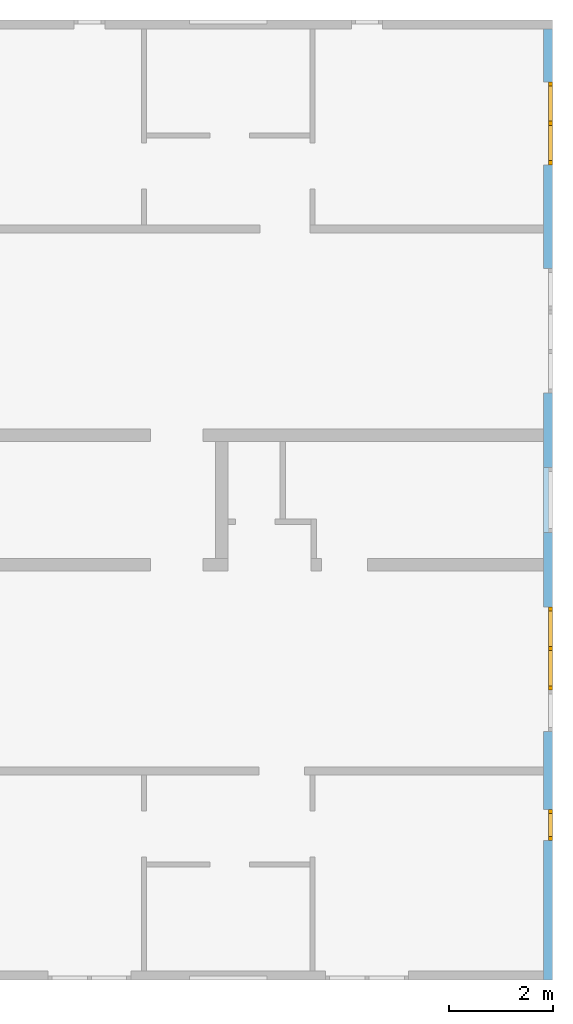
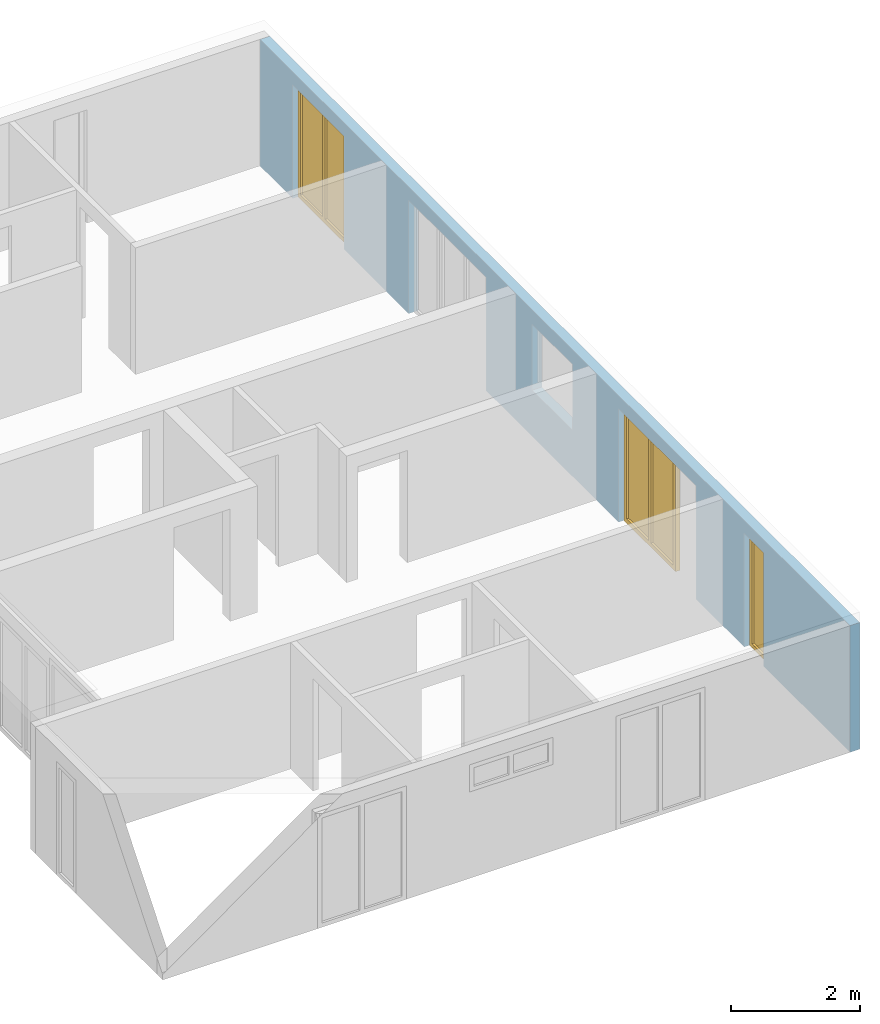
# One storey, part 6 of 8: 3 windows, 7 openings, plus 1 element that does not belong to this part.
"""IFC2X3 building model written with IfcOpenShell, lengths in millimetres."""

from ifc_helpers import new_model, entity, si_unit, converted_unit, frame, frame_2d, origin, origin_with_axes, place, context, project, spatial, rectangle, extrude, faceted_brep, material, layer, layer_set, layer_usage, element, fill, save


model = new_model("IFC2X3")

# Units and contexts
model_context = context("Model", 3, precision=1e-05, world=origin())
plan_context = context("Plan", 3, precision=1e-05, world=origin())
ifc_project = project(units=[si_unit("LENGTHUNIT", "METRE", prefix="MILLI"), converted_unit("PLANEANGLEUNIT", "DEGREE", entity("IfcPlaneAngleMeasure", 0.0174532925199433), si_unit("PLANEANGLEUNIT", "RADIAN"), dimensions=[0, 0, 0, 0, 0, 0, 0]), si_unit("AREAUNIT", "SQUARE_METRE"), si_unit("VOLUMEUNIT", "CUBIC_METRE")], contexts=[model_context, plan_context])

# Building, storey
building_placement = place(None, origin())
building = spatial("IfcBuilding", under=ifc_project, at=building_placement, CompositionType="ELEMENT")
storey_placement = place(building_placement, frame((0.0, 0.0, 2900.0), z_axis=(0.0, 0.0, 1.0), x_axis=(1.0, 0.0, 0.0)))
storey = spatial("IfcBuildingStorey", under=building, at=storey_placement, Name="OG", CompositionType="ELEMENT", Elevation=2900.0)

# Wall, openings, windows
ifc_material_1 = material(Name="B25")
ifc_layer = layer(ifc_material_1, 175.000000044703)
ifc_layer_set = layer_set([ifc_layer])
ifc_layer_usage = layer_usage(ifc_layer_set, "AXIS2", "POSITIVE", 0.0)
wall_placement = place(storey_placement, frame((33688.3517822139, -8691.5625, 0.0), z_axis=(0.0, 0.0, 1.0), x_axis=(0.0, 1.0, 0.0)))
wall = element("IfcWallStandardCase", 1, at=wall_placement, inside=storey, material=ifc_layer_usage, context=model_context, shape_type="SweptSolid", body=[
    extrude(rectangle(XDim=18325.0, YDim=175.000000044703, at=frame_2d((9162.5, 87.5000000223517), x_axis=(1.0, 0.0))), origin_with_axes(), (0.0, 0.0, 1.0), 2400.0),
])
opening_1_placement = place(wall_placement, frame((2690.0, 0.0, 0.0), z_axis=(0.0, 1.0, 0.0), x_axis=(0.0, 0.0, 1.0)))
opening_1 = element("IfcOpeningElement", 2, at=opening_1_placement, cuts=wall, ObjectType="Opening", context=model_context, shape_type="SweptSolid", body=[
    extrude(rectangle(XDim=2150.0, YDim=600.0, at=frame_2d((1075.0, 300.0), x_axis=(1.0, 0.0))), origin_with_axes(), (0.0, 0.0, 1.0), 175.000000044703),
])
opening_2_placement = place(wall_placement, frame((5590.0, 0.0, 0.0), z_axis=(0.0, 1.0, 0.0), x_axis=(0.0, 0.0, 1.0)))
opening_2 = element("IfcOpeningElement", 3, at=opening_2_placement, cuts=wall, ObjectType="Opening", context=model_context, shape_type="SweptSolid", body=[
    extrude(rectangle(XDim=2150.0, YDim=1600.0, at=frame_2d((1075.0, 800.0), x_axis=(1.0, 0.0))), origin_with_axes(), (0.0, 0.0, 1.0), 175.000000044703),
])
opening_3_placement = place(wall_placement, frame((15710.0, 0.0, 0.0), z_axis=(0.0, 1.0, 0.0), x_axis=(0.0, 0.0, 1.0)))
opening_3 = element("IfcOpeningElement", 4, at=opening_3_placement, cuts=wall, ObjectType="Opening", context=model_context, shape_type="SweptSolid", body=[
    extrude(rectangle(XDim=2150.0, YDim=1600.0, at=frame_2d((1075.0, 800.0), x_axis=(1.0, 0.0))), origin_with_axes(), (0.0, 0.0, 1.0), 175.000000044703),
])
opening_4_placement = place(wall_placement, frame((8625.0, 1.86264514923096e-09, 875.0), z_axis=(0.0, 1.0, 0.0), x_axis=(0.0, 0.0, 1.0)))
element("IfcOpeningElement", 5, at=opening_4_placement, cuts=wall, ObjectType="Opening", context=model_context, shape_type="SweptSolid", body=[
    extrude(rectangle(XDim=1250.0, YDim=1250.0, at=frame_2d((625.0, 625.0), x_axis=(1.0, 0.0))), origin_with_axes(), (0.0, 0.0, 1.0), 175.000000044703),
])
opening_5_placement = place(wall_placement, frame((4790.0, 0.0, 0.0), z_axis=(0.0, 1.0, 0.0), x_axis=(0.0, 0.0, 1.0)))
element("IfcOpeningElement", 6, at=opening_5_placement, cuts=wall, ObjectType="Opening", context=model_context, shape_type="SweptSolid", body=[
    extrude(rectangle(XDim=2150.0, YDim=800.0, at=frame_2d((1075.0, 400.0), x_axis=(1.0, 0.0))), origin_with_axes(), (0.0, 0.0, 1.0), 175.000000044703),
])
opening_6_placement = place(wall_placement, frame((12910.0, 0.0, 0.0), z_axis=(0.0, 1.0, 0.0), x_axis=(0.0, 0.0, 1.0)))
element("IfcOpeningElement", 7, at=opening_6_placement, cuts=wall, ObjectType="Opening", context=model_context, shape_type="SweptSolid", body=[
    extrude(rectangle(XDim=2150.0, YDim=800.0, at=frame_2d((1075.0, 400.0), x_axis=(1.0, 0.0))), origin_with_axes(), (0.0, 0.0, 1.0), 175.000000044703),
])
opening_7_placement = place(wall_placement, frame((11310.0, 0.0, 0.0), z_axis=(0.0, 1.0, 0.0), x_axis=(0.0, 0.0, 1.0)))
element("IfcOpeningElement", 8, at=opening_7_placement, cuts=wall, ObjectType="Opening", context=model_context, shape_type="SweptSolid", body=[
    extrude(rectangle(XDim=2150.0, YDim=1600.0, at=frame_2d((1075.0, 800.0), x_axis=(1.0, 0.0))), origin_with_axes(), (0.0, 0.0, 1.0), 175.000000044703),
])
ifc_material_2 = material()
window_1_placement = place(opening_1_placement, frame((0.0, 0.0, 0.0), z_axis=(1.0, 0.0, 0.0), x_axis=(0.0, 1.0, 0.0)))
window_1 = element("IfcWindow", 9, at=window_1_placement, inside=storey, material=ifc_material_2, Name="m", OverallHeight=2150.0, OverallWidth=600.0, context=model_context, shape_type="Brep", body=[
    faceted_brep([(520.0, 4.16384704493566e-11, 0.0), (520.0, 4.16384704493566e-11, 2150.0), (600.0, 4.16237044831291e-11, 2150.0), (600.0, 4.16237044831291e-11, 0.0), (600.0, 80.0000000000416, 0.0), (600.0, 80.0000000000416, 2150.0), (520.0, 80.0000000000416, 2150.0), (520.0, 80.0000000000416, 0.0), (600.0, 4.16237044831291e-11, 0.0), (600.0, 80.0000000000416, 0.0), (520.0, 80.0000000000416, 0.0), (520.0, 4.16384704493566e-11, 0.0), (600.0, 4.16237044831291e-11, 2150.0), (600.0, 80.0000000000416, 2150.0), (600.0, 80.0000000000416, 0.0), (600.0, 4.16237044831291e-11, 0.0), (520.0, 4.16384704493566e-11, 2150.0), (520.0, 80.0000000000416, 2150.0), (600.0, 80.0000000000416, 2150.0), (600.0, 4.16237044831291e-11, 2150.0), (520.0, 4.16384704493566e-11, 0.0), (520.0, 80.0000000000416, 0.0), (520.0, 80.0000000000416, 2150.0), (520.0, 4.16384704493566e-11, 2150.0)], [[[0, 1, 2, 3]], [[4, 5, 6, 7]], [[8, 9, 10, 11]], [[12, 13, 14, 15]], [[16, 17, 18, 19]], [[20, 21, 22, 23]]], orient=[[False], [False], [False], [False], [False], [False]]),
    faceted_brep([(80.0, 4.17335055402646e-11, 2150.0), (80.0, 4.17335055402646e-11, 0.0), (-1.10214571841424e-16, 4.17481604841896e-11, 0.0), (-1.10214571841424e-16, 4.17481604841896e-11, 2150.0), (1.45850616740271e-14, 80.0000000000418, 2150.0), (1.45850616740271e-14, 80.0000000000418, 0.0), (80.0, 80.0000000000417, 0.0), (80.0, 80.0000000000417, 2150.0), (-1.10214571841424e-16, 4.17481604841896e-11, 2150.0), (1.45850616740271e-14, 80.0000000000418, 2150.0), (80.0, 80.0000000000417, 2150.0), (80.0, 4.17335055402646e-11, 2150.0), (-1.10214571841424e-16, 4.17481604841896e-11, 0.0), (1.45850616740271e-14, 80.0000000000418, 0.0), (1.45850616740271e-14, 80.0000000000418, 2150.0), (-1.10214571841424e-16, 4.17481604841896e-11, 2150.0), (80.0, 4.17335055402646e-11, 0.0), (80.0, 80.0000000000417, 0.0), (1.45850616740271e-14, 80.0000000000418, 0.0), (-1.10214571841424e-16, 4.17481604841896e-11, 0.0), (80.0, 4.17335055402646e-11, 2150.0), (80.0, 80.0000000000417, 2150.0), (80.0, 80.0000000000417, 0.0), (80.0, 4.17335055402646e-11, 0.0)], [[[0, 1, 2, 3]], [[4, 5, 6, 7]], [[8, 9, 10, 11]], [[12, 13, 14, 15]], [[16, 17, 18, 19]], [[20, 21, 22, 23]]], orient=[[False], [False], [False], [False], [False], [False]]),
    faceted_brep([(520.0, 4.16668921587871e-11, 2070.0), (80.0, 4.17477163949798e-11, 2070.0), (80.0, 4.17477163949798e-11, 2150.0), (520.0, 4.16668921587871e-11, 2150.0), (520.0, 80.0000000000417, 2150.0), (80.0, 80.0000000000418, 2150.0), (80.0, 80.0000000000418, 2070.0), (520.0, 80.0000000000417, 2070.0), (520.0, 4.16668921587871e-11, 2150.0), (520.0, 80.0000000000417, 2150.0), (520.0, 80.0000000000417, 2070.0), (520.0, 4.16668921587871e-11, 2070.0), (80.0, 4.17477163949798e-11, 2150.0), (80.0, 80.0000000000418, 2150.0), (520.0, 80.0000000000417, 2150.0), (520.0, 4.16668921587871e-11, 2150.0), (80.0, 4.17477163949798e-11, 2070.0), (80.0, 80.0000000000418, 2070.0), (80.0, 80.0000000000418, 2150.0), (80.0, 4.17477163949798e-11, 2150.0), (520.0, 4.16668921587871e-11, 2070.0), (520.0, 80.0000000000417, 2070.0), (80.0, 80.0000000000418, 2070.0), (80.0, 4.17477163949798e-11, 2070.0)], [[[0, 1, 2, 3]], [[4, 5, 6, 7]], [[8, 9, 10, 11]], [[12, 13, 14, 15]], [[16, 17, 18, 19]], [[20, 21, 22, 23]]], orient=[[False], [False], [False], [False], [False], [False]]),
    faceted_brep([(80.0, 4.17477163949798e-11, 80.0), (520.0, 4.16668921587871e-11, 80.0), (520.0, 4.16668921587871e-11, 0.0), (80.0, 4.17477163949798e-11, 0.0), (80.0, 80.0000000000418, 0.0), (520.0, 80.0000000000417, 0.0), (520.0, 80.0000000000417, 80.0), (80.0, 80.0000000000418, 80.0), (80.0, 4.17477163949798e-11, 0.0), (80.0, 80.0000000000418, 0.0), (80.0, 80.0000000000418, 80.0), (80.0, 4.17477163949798e-11, 80.0), (520.0, 4.16668921587871e-11, 0.0), (520.0, 80.0000000000417, 0.0), (80.0, 80.0000000000418, 0.0), (80.0, 4.17477163949798e-11, 0.0), (520.0, 4.16668921587871e-11, 80.0), (520.0, 80.0000000000417, 80.0), (520.0, 80.0000000000417, 0.0), (520.0, 4.16668921587871e-11, 0.0), (80.0, 4.17477163949798e-11, 80.0), (80.0, 80.0000000000418, 80.0), (520.0, 80.0000000000417, 80.0), (520.0, 4.16668921587871e-11, 80.0)], [[[0, 1, 2, 3]], [[4, 5, 6, 7]], [[8, 9, 10, 11]], [[12, 13, 14, 15]], [[16, 17, 18, 19]], [[20, 21, 22, 23]]], orient=[[False], [False], [False], [False], [False], [False]]),
    faceted_brep([(520.0, 40.0000000000417, 80.0), (80.0, 40.0000000000418, 80.0), (80.0, 40.0000000000418, 2070.0), (520.0, 40.0000000000417, 2070.0), (520.0, 41.0000000000417, 80.0), (520.0, 41.0000000000417, 2070.0), (80.0, 41.0000000000418, 2070.0), (80.0, 41.0000000000418, 80.0), (520.0, 40.0000000000417, 80.0), (520.0, 41.0000000000417, 80.0), (80.0, 41.0000000000418, 80.0), (80.0, 40.0000000000418, 80.0), (80.0, 40.0000000000418, 80.0), (80.0, 41.0000000000418, 80.0), (80.0, 41.0000000000418, 2070.0), (80.0, 40.0000000000418, 2070.0), (80.0, 40.0000000000418, 2070.0), (80.0, 41.0000000000418, 2070.0), (520.0, 41.0000000000417, 2070.0), (520.0, 40.0000000000417, 2070.0), (520.0, 40.0000000000417, 2070.0), (520.0, 41.0000000000417, 2070.0), (520.0, 41.0000000000417, 80.0), (520.0, 40.0000000000417, 80.0)], [[[0, 1, 2, 3]], [[4, 5, 6, 7]], [[8, 9, 10, 11]], [[12, 13, 14, 15]], [[16, 17, 18, 19]], [[20, 21, 22, 23]]], orient=[[False], [False], [False], [False], [False], [False]]),
])
fill(opening_1, window_1)
ifc_material_3 = material()
window_2_placement = place(opening_2_placement, frame((0.0, 0.0, 0.0), z_axis=(1.0, 0.0, 0.0), x_axis=(0.0, 1.0, 0.0)))
window_2 = element("IfcWindow", 10, at=window_2_placement, inside=storey, material=ifc_material_3, Name="m", OverallHeight=2150.0, OverallWidth=1600.0, context=model_context, shape_type="Brep", body=[
    faceted_brep([(1520.0, 4.14689393934964e-11, 0.0), (1520.0, 4.14689393934964e-11, 2150.0), (1600.0, 4.14542844495713e-11, 2150.0), (1600.0, 4.14542844495713e-11, 0.0), (1600.0, 80.0000000000415, 0.0), (1600.0, 80.0000000000415, 2150.0), (1520.0, 80.0000000000415, 2150.0), (1520.0, 80.0000000000415, 0.0), (1600.0, 4.14542844495713e-11, 0.0), (1600.0, 80.0000000000415, 0.0), (1520.0, 80.0000000000415, 0.0), (1520.0, 4.14689393934964e-11, 0.0), (1600.0, 4.14542844495713e-11, 2150.0), (1600.0, 80.0000000000415, 2150.0), (1600.0, 80.0000000000415, 0.0), (1600.0, 4.14542844495713e-11, 0.0), (1520.0, 4.14689393934964e-11, 2150.0), (1520.0, 80.0000000000415, 2150.0), (1600.0, 80.0000000000415, 2150.0), (1600.0, 4.14542844495713e-11, 2150.0), (1520.0, 4.14689393934964e-11, 0.0), (1520.0, 80.0000000000415, 0.0), (1520.0, 80.0000000000415, 2150.0), (1520.0, 4.14689393934964e-11, 2150.0)], [[[0, 1, 2, 3]], [[4, 5, 6, 7]], [[8, 9, 10, 11]], [[12, 13, 14, 15]], [[16, 17, 18, 19]], [[20, 21, 22, 23]]], orient=[[False], [False], [False], [False], [False], [False]]),
    faceted_brep([(80.0, 4.17335055402646e-11, 2150.0), (80.0, 4.17335055402646e-11, 0.0), (-1.10214571841424e-16, 4.17481604841896e-11, 0.0), (-1.10214571841424e-16, 4.17481604841896e-11, 2150.0), (1.45850616740271e-14, 80.0000000000418, 2150.0), (1.45850616740271e-14, 80.0000000000418, 0.0), (80.0, 80.0000000000417, 0.0), (80.0, 80.0000000000417, 2150.0), (-1.10214571841424e-16, 4.17481604841896e-11, 2150.0), (1.45850616740271e-14, 80.0000000000418, 2150.0), (80.0, 80.0000000000417, 2150.0), (80.0, 4.17335055402646e-11, 2150.0), (-1.10214571841424e-16, 4.17481604841896e-11, 0.0), (1.45850616740271e-14, 80.0000000000418, 0.0), (1.45850616740271e-14, 80.0000000000418, 2150.0), (-1.10214571841424e-16, 4.17481604841896e-11, 2150.0), (80.0, 4.17335055402646e-11, 0.0), (80.0, 80.0000000000417, 0.0), (1.45850616740271e-14, 80.0000000000418, 0.0), (-1.10214571841424e-16, 4.17481604841896e-11, 0.0), (80.0, 4.17335055402646e-11, 2150.0), (80.0, 80.0000000000417, 2150.0), (80.0, 80.0000000000417, 0.0), (80.0, 4.17335055402646e-11, 0.0)], [[[0, 1, 2, 3]], [[4, 5, 6, 7]], [[8, 9, 10, 11]], [[12, 13, 14, 15]], [[16, 17, 18, 19]], [[20, 21, 22, 23]]], orient=[[False], [False], [False], [False], [False], [False]]),
    faceted_brep([(1520.0, 4.14831502482116e-11, 2070.0), (80.0, 4.17477163949798e-11, 2070.0), (80.0, 4.17477163949798e-11, 2150.0), (1520.0, 4.14831502482116e-11, 2150.0), (1520.0, 80.0000000000415, 2150.0), (80.0, 80.0000000000418, 2150.0), (80.0, 80.0000000000418, 2070.0), (1520.0, 80.0000000000415, 2070.0), (1520.0, 4.14831502482116e-11, 2150.0), (1520.0, 80.0000000000415, 2150.0), (1520.0, 80.0000000000415, 2070.0), (1520.0, 4.14831502482116e-11, 2070.0), (80.0, 4.17477163949798e-11, 2150.0), (80.0, 80.0000000000418, 2150.0), (1520.0, 80.0000000000415, 2150.0), (1520.0, 4.14831502482116e-11, 2150.0), (80.0, 4.17477163949798e-11, 2070.0), (80.0, 80.0000000000418, 2070.0), (80.0, 80.0000000000418, 2150.0), (80.0, 4.17477163949798e-11, 2150.0), (1520.0, 4.14831502482116e-11, 2070.0), (1520.0, 80.0000000000415, 2070.0), (80.0, 80.0000000000418, 2070.0), (80.0, 4.17477163949798e-11, 2070.0)], [[[0, 1, 2, 3]], [[4, 5, 6, 7]], [[8, 9, 10, 11]], [[12, 13, 14, 15]], [[16, 17, 18, 19]], [[20, 21, 22, 23]]], orient=[[False], [False], [False], [False], [False], [False]]),
    faceted_brep([(80.0, 4.17477163949798e-11, 80.0), (1520.0, 4.14831502482116e-11, 80.0), (1520.0, 4.14831502482116e-11, 0.0), (80.0, 4.17477163949798e-11, 0.0), (80.0, 80.0000000000418, 0.0), (1520.0, 80.0000000000415, 0.0), (1520.0, 80.0000000000415, 80.0), (80.0, 80.0000000000418, 80.0), (80.0, 4.17477163949798e-11, 0.0), (80.0, 80.0000000000418, 0.0), (80.0, 80.0000000000418, 80.0), (80.0, 4.17477163949798e-11, 80.0), (1520.0, 4.14831502482116e-11, 0.0), (1520.0, 80.0000000000415, 0.0), (80.0, 80.0000000000418, 0.0), (80.0, 4.17477163949798e-11, 0.0), (1520.0, 4.14831502482116e-11, 80.0), (1520.0, 80.0000000000415, 80.0), (1520.0, 80.0000000000415, 0.0), (1520.0, 4.14831502482116e-11, 0.0), (80.0, 4.17477163949798e-11, 80.0), (80.0, 80.0000000000418, 80.0), (1520.0, 80.0000000000415, 80.0), (1520.0, 4.14831502482116e-11, 80.0)], [[[0, 1, 2, 3]], [[4, 5, 6, 7]], [[8, 9, 10, 11]], [[12, 13, 14, 15]], [[16, 17, 18, 19]], [[20, 21, 22, 23]]], orient=[[False], [False], [False], [False], [False], [False]]),
    faceted_brep([(760.0, 4.16086054499942e-11, 80.0), (760.0, 4.16086054499942e-11, 2070.0), (840.0, 4.15938394837667e-11, 2070.0), (840.0, 4.15938394837667e-11, 80.0), (840.0, 80.0000000000416, 80.0), (840.0, 80.0000000000416, 2070.0), (760.0, 80.0000000000416, 2070.0), (760.0, 80.0000000000416, 80.0), (840.0, 4.15938394837667e-11, 80.0), (840.0, 80.0000000000416, 80.0), (760.0, 80.0000000000416, 80.0), (760.0, 4.16086054499942e-11, 80.0), (840.0, 4.15938394837667e-11, 2070.0), (840.0, 80.0000000000416, 2070.0), (840.0, 80.0000000000416, 80.0), (840.0, 4.15938394837667e-11, 80.0), (760.0, 4.16086054499942e-11, 2070.0), (760.0, 80.0000000000416, 2070.0), (840.0, 80.0000000000416, 2070.0), (840.0, 4.15938394837667e-11, 2070.0), (760.0, 4.16086054499942e-11, 80.0), (760.0, 80.0000000000416, 80.0), (760.0, 80.0000000000416, 2070.0), (760.0, 4.16086054499942e-11, 2070.0)], [[[0, 1, 2, 3]], [[4, 5, 6, 7]], [[8, 9, 10, 11]], [[12, 13, 14, 15]], [[16, 17, 18, 19]], [[20, 21, 22, 23]]], orient=[[False], [False], [False], [False], [False], [False]]),
    faceted_brep([(80.0, 40.0000000000418, 2070.0), (760.0, 40.0000000000416, 2070.0), (760.0, 40.0000000000416, 80.0), (80.0, 40.0000000000418, 80.0), (80.0, 41.0000000000418, 2070.0), (80.0, 41.0000000000418, 80.0), (760.0, 41.0000000000416, 80.0), (760.0, 41.0000000000416, 2070.0), (80.0, 40.0000000000418, 2070.0), (80.0, 41.0000000000418, 2070.0), (760.0, 41.0000000000416, 2070.0), (760.0, 40.0000000000416, 2070.0), (760.0, 40.0000000000416, 2070.0), (760.0, 41.0000000000416, 2070.0), (760.0, 41.0000000000416, 80.0), (760.0, 40.0000000000416, 80.0), (760.0, 40.0000000000416, 80.0), (760.0, 41.0000000000416, 80.0), (80.0, 41.0000000000418, 80.0), (80.0, 40.0000000000418, 80.0), (80.0, 40.0000000000418, 80.0), (80.0, 41.0000000000418, 80.0), (80.0, 41.0000000000418, 2070.0), (80.0, 40.0000000000418, 2070.0)], [[[0, 1, 2, 3]], [[4, 5, 6, 7]], [[8, 9, 10, 11]], [[12, 13, 14, 15]], [[16, 17, 18, 19]], [[20, 21, 22, 23]]], orient=[[False], [False], [False], [False], [False], [False]]),
    faceted_brep([(1520.0, 40.0000000000415, 80.0), (840.0, 40.0000000000416, 80.0), (840.0, 40.0000000000416, 2070.0), (1520.0, 40.0000000000415, 2070.0), (1520.0, 41.0000000000415, 80.0), (1520.0, 41.0000000000415, 2070.0), (840.0, 41.0000000000416, 2070.0), (840.0, 41.0000000000416, 80.0), (1520.0, 40.0000000000415, 80.0), (1520.0, 41.0000000000415, 80.0), (840.0, 41.0000000000416, 80.0), (840.0, 40.0000000000416, 80.0), (840.0, 40.0000000000416, 80.0), (840.0, 41.0000000000416, 80.0), (840.0, 41.0000000000416, 2070.0), (840.0, 40.0000000000416, 2070.0), (840.0, 40.0000000000416, 2070.0), (840.0, 41.0000000000416, 2070.0), (1520.0, 41.0000000000415, 2070.0), (1520.0, 40.0000000000415, 2070.0), (1520.0, 40.0000000000415, 2070.0), (1520.0, 41.0000000000415, 2070.0), (1520.0, 41.0000000000415, 80.0), (1520.0, 40.0000000000415, 80.0)], [[[0, 1, 2, 3]], [[4, 5, 6, 7]], [[8, 9, 10, 11]], [[12, 13, 14, 15]], [[16, 17, 18, 19]], [[20, 21, 22, 23]]], orient=[[False], [False], [False], [False], [False], [False]]),
])
fill(opening_2, window_2)
ifc_material_4 = material()
window_3_placement = place(opening_3_placement, frame((0.0, 0.0, 0.0), z_axis=(1.0, 0.0, 0.0), x_axis=(0.0, 1.0, 0.0)))
window_3 = element("IfcWindow", 11, at=window_3_placement, inside=storey, material=ifc_material_4, Name="m", OverallHeight=2150.0, OverallWidth=1600.0, context=model_context, shape_type="Brep", body=[
    faceted_brep([(1520.0, 4.14689393934964e-11, 0.0), (1520.0, 4.14689393934964e-11, 2150.0), (1600.0, 4.14542844495713e-11, 2150.0), (1600.0, 4.14542844495713e-11, 0.0), (1600.0, 80.0000000000415, 0.0), (1600.0, 80.0000000000415, 2150.0), (1520.0, 80.0000000000415, 2150.0), (1520.0, 80.0000000000415, 0.0), (1600.0, 4.14542844495713e-11, 0.0), (1600.0, 80.0000000000415, 0.0), (1520.0, 80.0000000000415, 0.0), (1520.0, 4.14689393934964e-11, 0.0), (1600.0, 4.14542844495713e-11, 2150.0), (1600.0, 80.0000000000415, 2150.0), (1600.0, 80.0000000000415, 0.0), (1600.0, 4.14542844495713e-11, 0.0), (1520.0, 4.14689393934964e-11, 2150.0), (1520.0, 80.0000000000415, 2150.0), (1600.0, 80.0000000000415, 2150.0), (1600.0, 4.14542844495713e-11, 2150.0), (1520.0, 4.14689393934964e-11, 0.0), (1520.0, 80.0000000000415, 0.0), (1520.0, 80.0000000000415, 2150.0), (1520.0, 4.14689393934964e-11, 2150.0)], [[[0, 1, 2, 3]], [[4, 5, 6, 7]], [[8, 9, 10, 11]], [[12, 13, 14, 15]], [[16, 17, 18, 19]], [[20, 21, 22, 23]]], orient=[[False], [False], [False], [False], [False], [False]]),
    faceted_brep([(80.0, 4.17335055402646e-11, 2150.0), (80.0, 4.17335055402646e-11, 0.0), (-1.10214571841424e-16, 4.17481604841896e-11, 0.0), (-1.10214571841424e-16, 4.17481604841896e-11, 2150.0), (1.45850616740271e-14, 80.0000000000418, 2150.0), (1.45850616740271e-14, 80.0000000000418, 0.0), (80.0, 80.0000000000417, 0.0), (80.0, 80.0000000000417, 2150.0), (-1.10214571841424e-16, 4.17481604841896e-11, 2150.0), (1.45850616740271e-14, 80.0000000000418, 2150.0), (80.0, 80.0000000000417, 2150.0), (80.0, 4.17335055402646e-11, 2150.0), (-1.10214571841424e-16, 4.17481604841896e-11, 0.0), (1.45850616740271e-14, 80.0000000000418, 0.0), (1.45850616740271e-14, 80.0000000000418, 2150.0), (-1.10214571841424e-16, 4.17481604841896e-11, 2150.0), (80.0, 4.17335055402646e-11, 0.0), (80.0, 80.0000000000417, 0.0), (1.45850616740271e-14, 80.0000000000418, 0.0), (-1.10214571841424e-16, 4.17481604841896e-11, 0.0), (80.0, 4.17335055402646e-11, 2150.0), (80.0, 80.0000000000417, 2150.0), (80.0, 80.0000000000417, 0.0), (80.0, 4.17335055402646e-11, 0.0)], [[[0, 1, 2, 3]], [[4, 5, 6, 7]], [[8, 9, 10, 11]], [[12, 13, 14, 15]], [[16, 17, 18, 19]], [[20, 21, 22, 23]]], orient=[[False], [False], [False], [False], [False], [False]]),
    faceted_brep([(1520.0, 4.14831502482116e-11, 2070.0), (80.0, 4.17477163949798e-11, 2070.0), (80.0, 4.17477163949798e-11, 2150.0), (1520.0, 4.14831502482116e-11, 2150.0), (1520.0, 80.0000000000415, 2150.0), (80.0, 80.0000000000418, 2150.0), (80.0, 80.0000000000418, 2070.0), (1520.0, 80.0000000000415, 2070.0), (1520.0, 4.14831502482116e-11, 2150.0), (1520.0, 80.0000000000415, 2150.0), (1520.0, 80.0000000000415, 2070.0), (1520.0, 4.14831502482116e-11, 2070.0), (80.0, 4.17477163949798e-11, 2150.0), (80.0, 80.0000000000418, 2150.0), (1520.0, 80.0000000000415, 2150.0), (1520.0, 4.14831502482116e-11, 2150.0), (80.0, 4.17477163949798e-11, 2070.0), (80.0, 80.0000000000418, 2070.0), (80.0, 80.0000000000418, 2150.0), (80.0, 4.17477163949798e-11, 2150.0), (1520.0, 4.14831502482116e-11, 2070.0), (1520.0, 80.0000000000415, 2070.0), (80.0, 80.0000000000418, 2070.0), (80.0, 4.17477163949798e-11, 2070.0)], [[[0, 1, 2, 3]], [[4, 5, 6, 7]], [[8, 9, 10, 11]], [[12, 13, 14, 15]], [[16, 17, 18, 19]], [[20, 21, 22, 23]]], orient=[[False], [False], [False], [False], [False], [False]]),
    faceted_brep([(80.0, 4.17477163949798e-11, 80.0), (1520.0, 4.14831502482116e-11, 80.0), (1520.0, 4.14831502482116e-11, 0.0), (80.0, 4.17477163949798e-11, 0.0), (80.0, 80.0000000000418, 0.0), (1520.0, 80.0000000000415, 0.0), (1520.0, 80.0000000000415, 80.0), (80.0, 80.0000000000418, 80.0), (80.0, 4.17477163949798e-11, 0.0), (80.0, 80.0000000000418, 0.0), (80.0, 80.0000000000418, 80.0), (80.0, 4.17477163949798e-11, 80.0), (1520.0, 4.14831502482116e-11, 0.0), (1520.0, 80.0000000000415, 0.0), (80.0, 80.0000000000418, 0.0), (80.0, 4.17477163949798e-11, 0.0), (1520.0, 4.14831502482116e-11, 80.0), (1520.0, 80.0000000000415, 80.0), (1520.0, 80.0000000000415, 0.0), (1520.0, 4.14831502482116e-11, 0.0), (80.0, 4.17477163949798e-11, 80.0), (80.0, 80.0000000000418, 80.0), (1520.0, 80.0000000000415, 80.0), (1520.0, 4.14831502482116e-11, 80.0)], [[[0, 1, 2, 3]], [[4, 5, 6, 7]], [[8, 9, 10, 11]], [[12, 13, 14, 15]], [[16, 17, 18, 19]], [[20, 21, 22, 23]]], orient=[[False], [False], [False], [False], [False], [False]]),
    faceted_brep([(760.0, 4.16086054499942e-11, 80.0), (760.0, 4.16086054499942e-11, 2070.0), (840.0, 4.15938394837667e-11, 2070.0), (840.0, 4.15938394837667e-11, 80.0), (840.0, 80.0000000000416, 80.0), (840.0, 80.0000000000416, 2070.0), (760.0, 80.0000000000416, 2070.0), (760.0, 80.0000000000416, 80.0), (840.0, 4.15938394837667e-11, 80.0), (840.0, 80.0000000000416, 80.0), (760.0, 80.0000000000416, 80.0), (760.0, 4.16086054499942e-11, 80.0), (840.0, 4.15938394837667e-11, 2070.0), (840.0, 80.0000000000416, 2070.0), (840.0, 80.0000000000416, 80.0), (840.0, 4.15938394837667e-11, 80.0), (760.0, 4.16086054499942e-11, 2070.0), (760.0, 80.0000000000416, 2070.0), (840.0, 80.0000000000416, 2070.0), (840.0, 4.15938394837667e-11, 2070.0), (760.0, 4.16086054499942e-11, 80.0), (760.0, 80.0000000000416, 80.0), (760.0, 80.0000000000416, 2070.0), (760.0, 4.16086054499942e-11, 2070.0)], [[[0, 1, 2, 3]], [[4, 5, 6, 7]], [[8, 9, 10, 11]], [[12, 13, 14, 15]], [[16, 17, 18, 19]], [[20, 21, 22, 23]]], orient=[[False], [False], [False], [False], [False], [False]]),
    faceted_brep([(80.0, 40.0000000000418, 2070.0), (760.0, 40.0000000000416, 2070.0), (760.0, 40.0000000000416, 80.0), (80.0, 40.0000000000418, 80.0), (80.0, 41.0000000000418, 2070.0), (80.0, 41.0000000000418, 80.0), (760.0, 41.0000000000416, 80.0), (760.0, 41.0000000000416, 2070.0), (80.0, 40.0000000000418, 2070.0), (80.0, 41.0000000000418, 2070.0), (760.0, 41.0000000000416, 2070.0), (760.0, 40.0000000000416, 2070.0), (760.0, 40.0000000000416, 2070.0), (760.0, 41.0000000000416, 2070.0), (760.0, 41.0000000000416, 80.0), (760.0, 40.0000000000416, 80.0), (760.0, 40.0000000000416, 80.0), (760.0, 41.0000000000416, 80.0), (80.0, 41.0000000000418, 80.0), (80.0, 40.0000000000418, 80.0), (80.0, 40.0000000000418, 80.0), (80.0, 41.0000000000418, 80.0), (80.0, 41.0000000000418, 2070.0), (80.0, 40.0000000000418, 2070.0)], [[[0, 1, 2, 3]], [[4, 5, 6, 7]], [[8, 9, 10, 11]], [[12, 13, 14, 15]], [[16, 17, 18, 19]], [[20, 21, 22, 23]]], orient=[[False], [False], [False], [False], [False], [False]]),
    faceted_brep([(1520.0, 40.0000000000415, 80.0), (840.0, 40.0000000000416, 80.0), (840.0, 40.0000000000416, 2070.0), (1520.0, 40.0000000000415, 2070.0), (1520.0, 41.0000000000415, 80.0), (1520.0, 41.0000000000415, 2070.0), (840.0, 41.0000000000416, 2070.0), (840.0, 41.0000000000416, 80.0), (1520.0, 40.0000000000415, 80.0), (1520.0, 41.0000000000415, 80.0), (840.0, 41.0000000000416, 80.0), (840.0, 40.0000000000416, 80.0), (840.0, 40.0000000000416, 80.0), (840.0, 41.0000000000416, 80.0), (840.0, 41.0000000000416, 2070.0), (840.0, 40.0000000000416, 2070.0), (840.0, 40.0000000000416, 2070.0), (840.0, 41.0000000000416, 2070.0), (1520.0, 41.0000000000415, 2070.0), (1520.0, 40.0000000000415, 2070.0), (1520.0, 40.0000000000415, 2070.0), (1520.0, 41.0000000000415, 2070.0), (1520.0, 41.0000000000415, 80.0), (1520.0, 40.0000000000415, 80.0)], [[[0, 1, 2, 3]], [[4, 5, 6, 7]], [[8, 9, 10, 11]], [[12, 13, 14, 15]], [[16, 17, 18, 19]], [[20, 21, 22, 23]]], orient=[[False], [False], [False], [False], [False], [False]]),
])
fill(opening_3, window_3)

save(model, "model.ifc")
